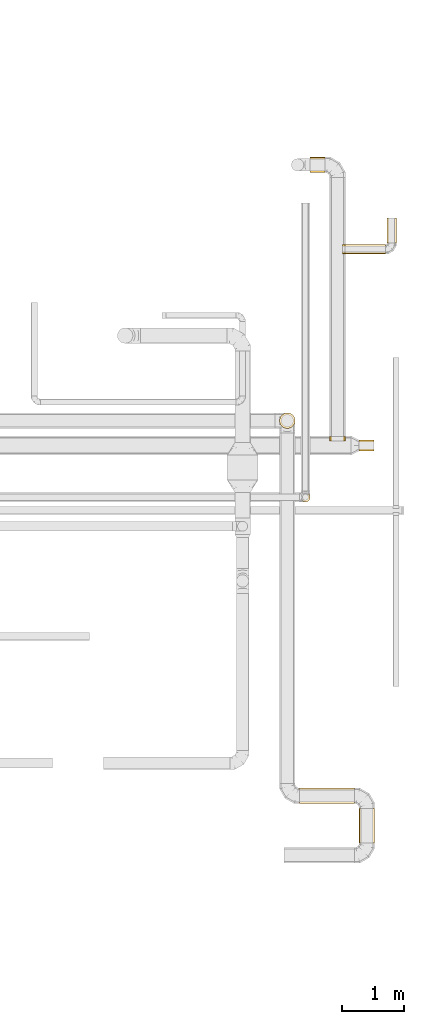
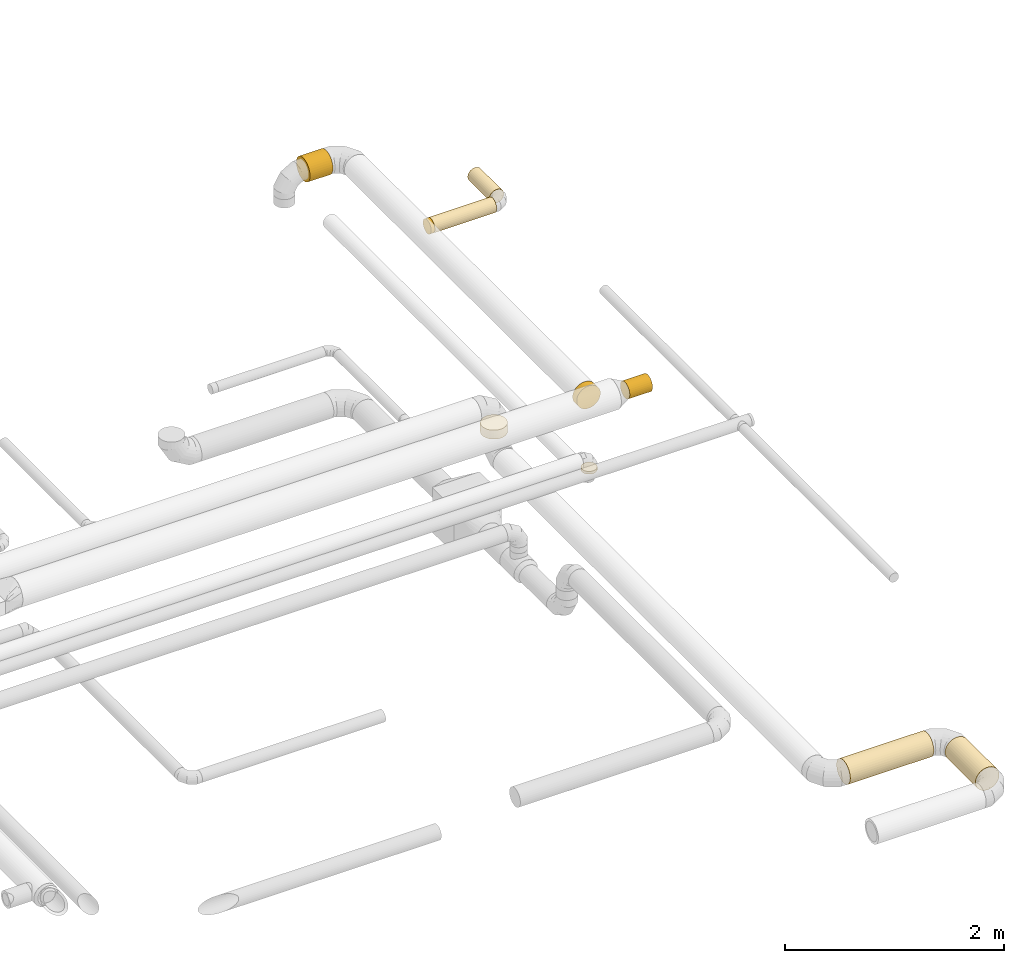
# One storey, part 7 of 92: 10 coverings.
"""IFC2X3 building model written with IfcOpenShell, lengths in millimetres."""

from ifc_helpers import new_model, entity, si_unit, converted_unit, derived_unit, direction, frame, origin, origin_2d_with_axis, place, context, subcontext, project, spatial, circle, extrude, element, save


model = new_model("IFC2X3")

# Units and contexts
model_context = context("Model", 3, precision=0.01, world=origin(), true_north=direction((6.12303176911189e-17, 1.0)))
body_context = subcontext(model_context, "Body", "Model", "MODEL_VIEW")
ifc_project = project(units=[si_unit("LENGTHUNIT", "METRE", prefix="MILLI"), si_unit("AREAUNIT", "SQUARE_METRE"), si_unit("VOLUMEUNIT", "CUBIC_METRE"), converted_unit("PLANEANGLEUNIT", "DEGREE", entity("IfcRatioMeasure", 0.0174532925199433), si_unit("PLANEANGLEUNIT", "RADIAN"), dimensions=[0, 0, 0, 0, 0, 0, 0]), si_unit("MASSUNIT", "GRAM", prefix="KILO"), derived_unit("MASSDENSITYUNIT", [(si_unit("MASSUNIT", "GRAM", prefix="KILO"), 1), (si_unit("LENGTHUNIT", "METRE"), -3)]), derived_unit("MOMENTOFINERTIAUNIT", [(si_unit("LENGTHUNIT", "METRE"), 4)]), si_unit("TIMEUNIT", "SECOND"), si_unit("FREQUENCYUNIT", "HERTZ"), si_unit("THERMODYNAMICTEMPERATUREUNIT", "DEGREE_CELSIUS"), derived_unit("THERMALTRANSMITTANCEUNIT", [(si_unit("MASSUNIT", "GRAM", prefix="KILO"), 1), (si_unit("THERMODYNAMICTEMPERATUREUNIT", "KELVIN"), -1), (si_unit("TIMEUNIT", "SECOND"), -3)]), derived_unit("VOLUMETRICFLOWRATEUNIT", [(si_unit("LENGTHUNIT", "METRE"), 3), (si_unit("TIMEUNIT", "SECOND"), -1)]), derived_unit("MASSFLOWRATEUNIT", [(si_unit("MASSUNIT", "GRAM", prefix="KILO"), 1), (si_unit("TIMEUNIT", "SECOND"), -1)]), derived_unit("ROTATIONALFREQUENCYUNIT", [(si_unit("TIMEUNIT", "SECOND"), -1)]), si_unit("ELECTRICCURRENTUNIT", "AMPERE"), si_unit("ELECTRICVOLTAGEUNIT", "VOLT"), si_unit("POWERUNIT", "WATT"), si_unit("FORCEUNIT", "NEWTON", prefix="KILO"), si_unit("ILLUMINANCEUNIT", "LUX"), si_unit("LUMINOUSFLUXUNIT", "LUMEN"), si_unit("LUMINOUSINTENSITYUNIT", "CANDELA"), derived_unit("USERDEFINED", [(si_unit("MASSUNIT", "GRAM", prefix="KILO"), -1), (si_unit("LENGTHUNIT", "METRE"), -2), (si_unit("TIMEUNIT", "SECOND"), 3), (si_unit("LUMINOUSFLUXUNIT", "LUMEN"), 1)]), derived_unit("LINEARVELOCITYUNIT", [(si_unit("LENGTHUNIT", "METRE"), 1), (si_unit("TIMEUNIT", "SECOND"), -1)]), si_unit("PRESSUREUNIT", "PASCAL"), derived_unit("USERDEFINED", [(si_unit("LENGTHUNIT", "METRE"), -2), (si_unit("MASSUNIT", "GRAM", prefix="KILO"), 1), (si_unit("TIMEUNIT", "SECOND"), -2)]), derived_unit("LINEARFORCEUNIT", [(si_unit("MASSUNIT", "GRAM", prefix="KILO"), 1), (si_unit("LENGTHUNIT", "METRE"), 1), (si_unit("TIMEUNIT", "SECOND"), -2), (si_unit("LENGTHUNIT", "METRE"), -1)]), derived_unit("PLANARFORCEUNIT", [(si_unit("MASSUNIT", "GRAM", prefix="KILO"), 1), (si_unit("LENGTHUNIT", "METRE"), 1), (si_unit("TIMEUNIT", "SECOND"), -2), (si_unit("LENGTHUNIT", "METRE"), -2)])], contexts=[model_context])

# Site, building, storey
site_placement = place(None, origin())
site = spatial("IfcSite", under=ifc_project, at=site_placement, CompositionType="ELEMENT")
building_placement = place(site_placement, origin())
building = spatial("IfcBuilding", under=site, at=building_placement, CompositionType="ELEMENT")
storey_placement = place(building_placement, frame((0.0, 0.0, 4200.0)))
storey = spatial("IfcBuildingStorey", under=building, at=storey_placement, CompositionType="ELEMENT", Elevation=4200.0)

# Coverings
covering_1_placement = place(storey_placement, frame((70850.06, 3810.73, 2673.4)))
element("IfcCovering", 1, at=covering_1_placement, inside=storey, PredefinedType="INSULATION", context=body_context, shape_type="SweptSolid", body=[
    extrude(circle(Radius=125.0, at=origin_2d_with_axis()), frame((0.0, 126.6, 126.6), z_axis=(1.0, 0.0, 0.0), x_axis=(0.0, 1.0, 0.0)), (0.0, 0.0, 1.0), 881.214399999986),
])
covering_2_placement = place(storey_placement, frame((71804.68, 3181.44, 2673.4)))
element("IfcCovering", 2, at=covering_2_placement, inside=storey, PredefinedType="INSULATION", context=body_context, shape_type="SweptSolid", body=[
    extrude(circle(Radius=125.0, at=origin_2d_with_axis()), frame((126.6, 0.0, 126.6), z_axis=(0.0, 1.0, 0.0), x_axis=(1.0, 0.0, 0.0)), (0.0, 0.0, 1.0), 555.884167898586),
])
covering_3_placement = place(storey_placement, frame((70523.47, 9848.33, 3000.0)))
element("IfcCovering", 3, at=covering_3_placement, inside=storey, PredefinedType="INSULATION", context=body_context, shape_type="SweptSolid", body=[
    extrude(circle(Radius=125.0, at=origin_2d_with_axis()), frame((126.6, 126.6, 0.0), z_axis=(0.0, 0.0, 1.0), x_axis=(0.0, -1.0, 0.0)), (0.0, 0.0, 1.0), 100.00000000002),
])
covering_4_placement = place(storey_placement, frame((71802.08, 9486.08, 3210.9)))
element("IfcCovering", 4, at=covering_4_placement, inside=storey, PredefinedType="INSULATION", context=body_context, shape_type="SweptSolid", body=[
    extrude(circle(Radius=87.5, at=origin_2d_with_axis()), frame((0.0, 89.1, 89.1), z_axis=(1.0, 0.0, 0.0), x_axis=(0.0, 1.0, 0.0)), (0.0, 0.0, 1.0), 239.999999999989),
])
covering_5_placement = place(storey_placement, frame((71577.65, 12657.45, 3223.4)))
element("IfcCovering", 5, at=covering_5_placement, inside=storey, PredefinedType="INSULATION", context=body_context, shape_type="SweptSolid", body=[
    extrude(circle(Radius=75.0, at=origin_2d_with_axis()), frame((0.0, 76.6, 76.6), z_axis=(1.0, 0.0, 0.0), x_axis=(0.0, 1.0, 0.0)), (0.0, 0.0, 1.0), 652.348698554637),
])
covering_6_placement = place(storey_placement, frame((72253.4, 12834.05, 3223.4)))
element("IfcCovering", 6, at=covering_6_placement, inside=storey, PredefinedType="INSULATION", context=body_context, shape_type="SweptSolid", body=[
    extrude(circle(Radius=75.0, at=origin_2d_with_axis()), frame((76.6, 0.0, 76.6), z_axis=(0.0, 1.0, 0.0), x_axis=(-1.0, 0.0, 0.0)), (0.0, 0.0, 1.0), 399.999999999989),
])
covering_7_placement = place(storey_placement, frame((71538.16, 12657.45, 3223.4)))
element("IfcCovering", 7, at=covering_7_placement, inside=storey, PredefinedType="INSULATION", context=body_context, shape_type="SweptSolid", body=[
    extrude(circle(Radius=75.0, at=origin_2d_with_axis()), frame((0.0, 76.6, 76.6), z_axis=(1.0, 0.0, 0.0), x_axis=(0.0, 1.0, 0.0)), (0.0, 0.0, 1.0), 39.4934596215442),
])
covering_8_placement = place(storey_placement, frame((71331.06, 9644.28, 3173.4)))
element("IfcCovering", 8, at=covering_8_placement, inside=storey, PredefinedType="INSULATION", context=body_context, shape_type="SweptSolid", body=[
    extrude(circle(Radius=125.0, at=origin_2d_with_axis()), frame((126.6, 0.0, 126.6), z_axis=(0.0, 1.0, 0.0), x_axis=(-1.0, 0.0, 0.0)), (0.0, 0.0, 1.0), 76.0959999999959),
])
covering_9_placement = place(storey_placement, frame((70865.99, 8666.09, 3220.0)))
element("IfcCovering", 9, at=covering_9_placement, inside=storey, PredefinedType="INSULATION", context=body_context, shape_type="SweptSolid", body=[
    extrude(circle(Radius=75.0, at=origin_2d_with_axis()), frame((76.6, 76.6, 0.0), z_axis=(0.0, 0.0, 1.0), x_axis=(0.0, -1.0, 0.0)), (0.0, 0.0, 1.0), 30.0000000000213),
])
covering_10_placement = place(storey_placement, frame((71015.36, 13963.52, 3173.4)))
element("IfcCovering", 10, at=covering_10_placement, inside=storey, PredefinedType="INSULATION", context=body_context, shape_type="SweptSolid", body=[
    extrude(circle(Radius=125.0, at=origin_2d_with_axis()), frame((0.0, 126.6, 126.6), z_axis=(1.0, 0.0, 0.0), x_axis=(0.0, -1.0, 0.0)), (0.0, 0.0, 1.0), 242.293439999617),
])

save(model, "model.ifc")
